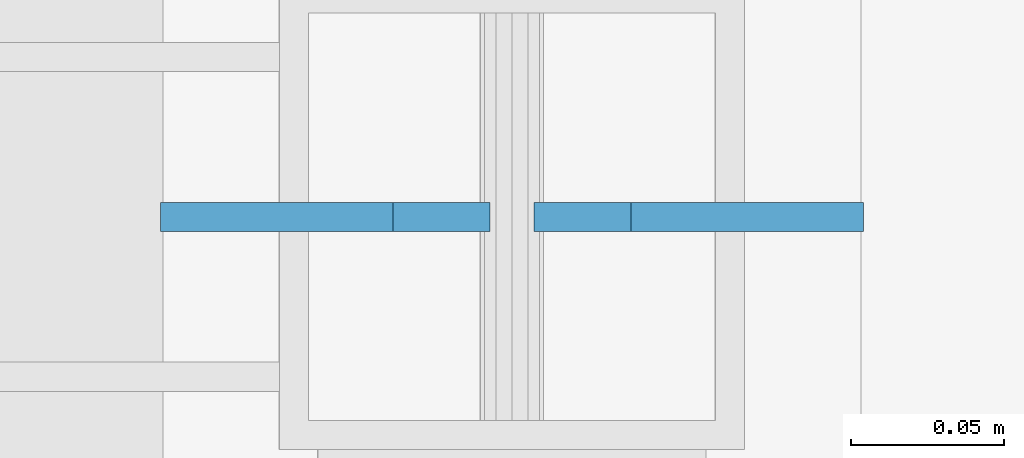
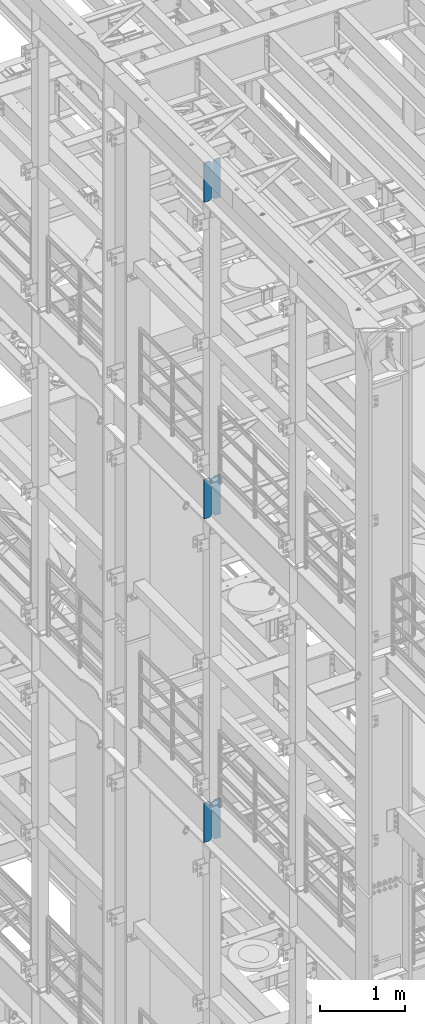
# One storey, part 1537 of 1876: 6 plates, 3 elements without a shape of their own.
"""IFC2X3 building model written with IfcOpenShell, lengths in millimetres."""

from ifc_helpers import new_model, si_unit, frame, origin_with_axes, place, context, subcontext, project, spatial, faceted_brep, material, type_object, element, aggregate, save


model = new_model("IFC2X3")

# Units and contexts
model_context = context("Model", 3, precision=1e-05, world=origin_with_axes())
body_context = subcontext(model_context, "Body", "Model", "MODEL_VIEW")
ifc_project = project(units=[si_unit("LENGTHUNIT", "METRE", prefix="MILLI"), si_unit("AREAUNIT", "SQUARE_METRE"), si_unit("VOLUMEUNIT", "CUBIC_METRE"), si_unit("MASSUNIT", "GRAM", prefix="KILO"), si_unit("TIMEUNIT", "SECOND"), si_unit("PLANEANGLEUNIT", "RADIAN"), si_unit("SOLIDANGLEUNIT", "STERADIAN"), si_unit("THERMODYNAMICTEMPERATUREUNIT", "DEGREE_CELSIUS"), si_unit("LUMINOUSINTENSITYUNIT", "LUMEN")], contexts=[model_context])

# Site, building, storey
site_placement = place(None, origin_with_axes())
site = spatial("IfcSite", under=ifc_project, at=site_placement, CompositionType="ELEMENT")
building_placement = place(site_placement, origin_with_axes())
building = spatial("IfcBuilding", under=site, at=building_placement, Name="Undefined", CompositionType="ELEMENT")
storey_placement = place(building_placement, origin_with_axes())
storey = spatial("IfcBuildingStorey", under=building, at=storey_placement, Name="Undefined", CompositionType="ELEMENT", Elevation=0.0)

# Assembly, plates
assembly_1_placement = place(storey_placement, origin_with_axes())
assembly_1 = element("IfcElementAssembly", 1, at=assembly_1_placement, inside=storey, Name="BEAM", AssemblyPlace="NOTDEFINED", PredefinedType="RIGID_FRAME")
ifc_material = material(Name="STEEL/A36")
plate_type = type_object("IfcPlateType", PredefinedType="NOTDEFINED")
plate_1_placement = place(assembly_1_placement, frame((115.093750395763, -508.000000015902, 21958.3), z_axis=(0.0, 0.0, 1.0), x_axis=(-1.0, 0.0, 0.0)))
plate_1 = element("IfcPlate", 2, at=plate_1_placement, type_object=plate_type, material=ifc_material, Name="PLATE", context=body_context, shape_type="Brep", body=[
    faceted_brep([(0.0, -4.76249999999982, 0.0), (0.0, -4.76249999999982, 571.5), (0.0, 4.76249999999982, 571.5), (0.0, 4.76249999999982, 0.0), (76.1999969482422, -4.76249999999982, 571.5), (76.1999969482422, 4.76249999999982, 571.5), (107.949996948242, -4.76249999999982, 539.75), (107.949996948242, 4.76249999999982, 539.75), (107.949996948242, -4.76249999999982, 31.75), (107.949996948242, 4.76249999999982, 31.75), (76.1999969482422, -4.76250000000073, 0.0), (76.1999969482422, 4.76250000000073, 0.0)], [[[0, 1, 2, 3]], [[1, 4, 5, 2]], [[4, 6, 7, 5]], [[6, 8, 9, 7]], [[8, 10, 11, 9]], [[10, 0, 3, 11]], [[5, 7, 9, 11, 3, 2]], [[10, 8, 6, 4, 1, 0]]]),
])
plate_2_placement = place(assembly_1_placement, frame((-7.14374960423695, -508.000000015902, 21958.3), z_axis=(0.0, 0.0, 1.0), x_axis=(-1.0, 0.0, 0.0)))
plate_2 = element("IfcPlate", 3, at=plate_2_placement, type_object=plate_type, material=ifc_material, Name="PLATE", context=body_context, shape_type="Brep", body=[
    faceted_brep([(-9.76996261670138e-14, -4.76250000000073, 31.75), (0.0, -4.76249999999982, 539.75), (0.0, 4.76249999999982, 539.75), (-9.76996261670138e-14, 4.76250000000073, 31.75), (31.75, -4.76249999999982, 571.5), (31.75, 4.76249999999982, 571.5), (107.949996948242, -4.76249999999982, 571.5), (107.949996948242, 4.76249999999982, 571.5), (107.950006484985, -4.76250000000073, 0.0), (107.950006484985, 4.76250000000073, 0.0), (31.75, -4.76250000000073, 0.0), (31.75, 4.76250000000073, 0.0)], [[[0, 1, 2, 3]], [[1, 4, 5, 2]], [[4, 6, 7, 5]], [[6, 8, 9, 7]], [[8, 10, 11, 9]], [[10, 0, 3, 11]], [[5, 7, 9, 11, 3, 2]], [[10, 8, 6, 4, 1, 0]]]),
])
aggregate(assembly_1, [plate_1, plate_2])

assembly_2_placement = place(storey_placement, origin_with_axes())
assembly_2 = element("IfcElementAssembly", 4, at=assembly_2_placement, inside=storey, Name="BEAM", AssemblyPlace="NOTDEFINED", PredefinedType="RIGID_FRAME")
plate_3_placement = place(assembly_2_placement, frame((115.093750395763, -508.000000015902, 17386.3), z_axis=(0.0, 0.0, 1.0), x_axis=(-1.0, 0.0, 0.0)))
plate_3 = element("IfcPlate", 5, at=plate_3_placement, type_object=plate_type, material=ifc_material, Name="PLATE", context=body_context, shape_type="Brep", body=[
    faceted_brep([(0.0, -4.76249999999982, 0.0), (0.0, -4.76249999999982, 571.5), (0.0, 4.76249999999982, 571.5), (0.0, 4.76249999999982, 0.0), (76.1999969482422, -4.76249999999982, 571.5), (76.1999969482422, 4.76249999999982, 571.5), (107.949996948242, -4.76249999999982, 539.75), (107.949996948242, 4.76249999999982, 539.75), (107.949996948242, -4.76249999999982, 31.75), (107.949996948242, 4.76249999999982, 31.75), (76.1999969482422, -4.76250000000073, 0.0), (76.1999969482422, 4.76250000000073, 0.0)], [[[0, 1, 2, 3]], [[1, 4, 5, 2]], [[4, 6, 7, 5]], [[6, 8, 9, 7]], [[8, 10, 11, 9]], [[10, 0, 3, 11]], [[5, 7, 9, 11, 3, 2]], [[10, 8, 6, 4, 1, 0]]]),
])
plate_4_placement = place(assembly_2_placement, frame((-7.14374960423695, -508.000000015902, 17386.3), z_axis=(0.0, 0.0, 1.0), x_axis=(-1.0, 0.0, 0.0)))
plate_4 = element("IfcPlate", 6, at=plate_4_placement, type_object=plate_type, material=ifc_material, Name="PLATE", context=body_context, shape_type="Brep", body=[
    faceted_brep([(-9.76996261670138e-14, -4.76250000000073, 31.75), (0.0, -4.76249999999982, 539.75), (0.0, 4.76249999999982, 539.75), (-9.76996261670138e-14, 4.76250000000073, 31.75), (31.75, -4.76249999999982, 571.5), (31.75, 4.76249999999982, 571.5), (107.949996948242, -4.76249999999982, 571.5), (107.949996948242, 4.76249999999982, 571.5), (107.950006484985, -4.76250000000073, 0.0), (107.950006484985, 4.76250000000073, 0.0), (31.75, -4.76250000000073, 0.0), (31.75, 4.76250000000073, 0.0)], [[[0, 1, 2, 3]], [[1, 4, 5, 2]], [[4, 6, 7, 5]], [[6, 8, 9, 7]], [[8, 10, 11, 9]], [[10, 0, 3, 11]], [[5, 7, 9, 11, 3, 2]], [[10, 8, 6, 4, 1, 0]]]),
])
aggregate(assembly_2, [plate_3, plate_4])

assembly_3_placement = place(storey_placement, origin_with_axes())
assembly_3 = element("IfcElementAssembly", 7, at=assembly_3_placement, inside=storey, Name="BEAM", AssemblyPlace="NOTDEFINED", PredefinedType="RIGID_FRAME")
plate_5_placement = place(assembly_3_placement, frame((115.093750395763, -508.000000015902, 12712.7), z_axis=(0.0, 0.0, 1.0), x_axis=(-1.0, 0.0, 0.0)))
plate_5 = element("IfcPlate", 8, at=plate_5_placement, type_object=plate_type, material=ifc_material, Name="PLATE", context=body_context, shape_type="Brep", body=[
    faceted_brep([(0.0, -4.76249999999982, 0.0), (0.0, -4.76249999999982, 571.5), (0.0, 4.76249999999982, 571.5), (0.0, 4.76249999999982, 0.0), (76.1999969482422, -4.76249999999982, 571.5), (76.1999969482422, 4.76249999999982, 571.5), (107.949996948242, -4.76249999999982, 539.75), (107.949996948242, 4.76249999999982, 539.75), (107.949996948242, -4.76249999999982, 31.75), (107.949996948242, 4.76249999999982, 31.75), (76.1999969482422, -4.76250000000073, 0.0), (76.1999969482422, 4.76250000000073, 0.0)], [[[0, 1, 2, 3]], [[1, 4, 5, 2]], [[4, 6, 7, 5]], [[6, 8, 9, 7]], [[8, 10, 11, 9]], [[10, 0, 3, 11]], [[5, 7, 9, 11, 3, 2]], [[10, 8, 6, 4, 1, 0]]]),
])
plate_6_placement = place(assembly_3_placement, frame((-7.14374960423695, -508.000000015902, 12712.7), z_axis=(0.0, 0.0, 1.0), x_axis=(-1.0, 0.0, 0.0)))
plate_6 = element("IfcPlate", 9, at=plate_6_placement, type_object=plate_type, material=ifc_material, Name="PLATE", context=body_context, shape_type="Brep", body=[
    faceted_brep([(-9.76996261670138e-14, -4.76250000000073, 31.75), (0.0, -4.76249999999982, 539.75), (0.0, 4.76249999999982, 539.75), (-9.76996261670138e-14, 4.76250000000073, 31.75), (31.75, -4.76249999999982, 571.5), (31.75, 4.76249999999982, 571.5), (107.949996948242, -4.76249999999982, 571.5), (107.949996948242, 4.76249999999982, 571.5), (107.950006484985, -4.76250000000073, 0.0), (107.950006484985, 4.76250000000073, 0.0), (31.75, -4.76250000000073, 0.0), (31.75, 4.76250000000073, 0.0)], [[[0, 1, 2, 3]], [[1, 4, 5, 2]], [[4, 6, 7, 5]], [[6, 8, 9, 7]], [[8, 10, 11, 9]], [[10, 0, 3, 11]], [[5, 7, 9, 11, 3, 2]], [[10, 8, 6, 4, 1, 0]]]),
])
aggregate(assembly_3, [plate_5, plate_6])

save(model, "model.ifc")
